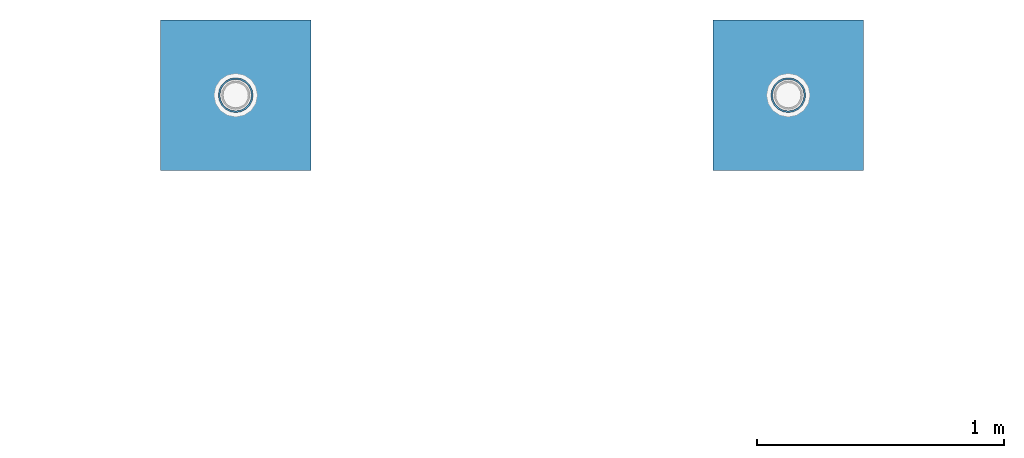
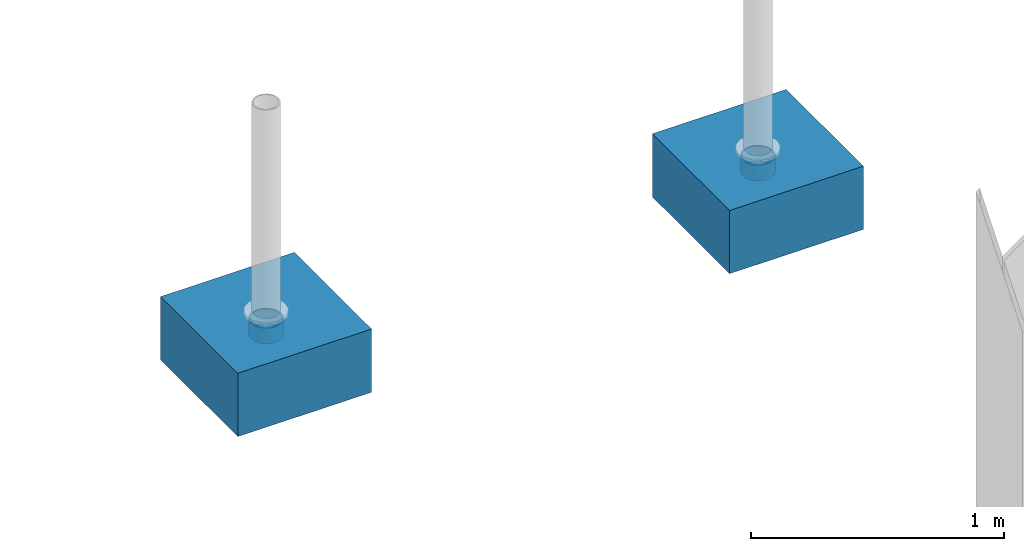
# One storey, part 1607 of 3843: 4 columns, 4 elements without a shape of their own.
"""IFC2X3 building model written with IfcOpenShell, lengths in millimetres."""

from ifc_helpers import new_model, si_unit, frame, origin_with_axes, place, context, subcontext, project, spatial, faceted_brep, material, type_object, element, aggregate, save


model = new_model("IFC2X3")

# Units and contexts
model_context = context("Model", 3, precision=1e-05, world=origin_with_axes())
body_context = subcontext(model_context, "Body", "Model", "MODEL_VIEW")
ifc_project = project(units=[si_unit("LENGTHUNIT", "METRE", prefix="MILLI"), si_unit("AREAUNIT", "SQUARE_METRE"), si_unit("VOLUMEUNIT", "CUBIC_METRE"), si_unit("MASSUNIT", "GRAM", prefix="KILO"), si_unit("TIMEUNIT", "SECOND"), si_unit("PLANEANGLEUNIT", "RADIAN"), si_unit("SOLIDANGLEUNIT", "STERADIAN"), si_unit("THERMODYNAMICTEMPERATUREUNIT", "DEGREE_CELSIUS"), si_unit("LUMINOUSINTENSITYUNIT", "LUMEN")], contexts=[model_context])

# Site, building, storey
site_placement = place(None, origin_with_axes())
site = spatial("IfcSite", under=ifc_project, at=site_placement, CompositionType="ELEMENT")
building_placement = place(site_placement, origin_with_axes())
building = spatial("IfcBuilding", under=site, at=building_placement, Name="Undefined", CompositionType="ELEMENT")
storey_placement = place(building_placement, origin_with_axes())
storey = spatial("IfcBuildingStorey", under=building, at=storey_placement, Name="Undefined", CompositionType="ELEMENT", Elevation=0.0)

# Assembly, column
assembly_1_placement = place(storey_placement, origin_with_axes())
assembly_1 = element("IfcElementAssembly", 1, at=assembly_1_placement, inside=storey, Name="PLATE", AssemblyPlace="NOTDEFINED", PredefinedType="RIGID_FRAME")
ifc_material_1 = material()
column_type_1 = type_object("IfcColumnType", Name="PIPE5SCH40", PredefinedType="NOTDEFINED")
column_1_placement = place(assembly_1_placement, frame((77051.0673368275, 106838.978119135, 30378.4), z_axis=(-1.0, 0.0, 0.0), x_axis=(0.0, 0.0, 1.0)))
column_1 = element("IfcColumn", 2, at=column_1_placement, type_object=column_type_1, material=ifc_material_1, Name="PIPE_SLEEVE", ObjectType="PIPE5SCH40", context=body_context, shape_type="Brep", body=[
    faceted_brep([(0.0, -64.0587999999998, 0.0), (0.0, -60.9235391660477, 19.7952578392724), (76.2000000000007, -60.9235391660477, 19.7952578392724), (76.2000000000007, -64.0587999999998, 0.0), (0.0, -51.8246578392655, 37.6528179195593), (76.2000000000007, -51.8246578392655, 37.6528179195593), (0.0, -37.6528179195529, 51.8246578392718), (76.2000000000007, -37.6528179195529, 51.8246578392718), (0.0, -19.795257839266, 60.9235391660477), (76.2000000000007, -19.795257839266, 60.9235391660477), (0.0, 0.0, 64.0587999999989), (76.2000000000007, 0.0, 64.0587999999989), (0.0, 19.795257839266, 60.9235391660477), (76.2000000000007, 19.795257839266, 60.9235391660477), (0.0, 37.6528179195529, 51.8246578392718), (76.2000000000007, 37.6528179195529, 51.8246578392718), (0.0, 51.8246578392655, 37.6528179195593), (76.2000000000007, 51.8246578392655, 37.6528179195593), (0.0, 60.9235391660477, 19.7952578392724), (76.2000000000007, 60.9235391660477, 19.7952578392724), (0.0, 64.0587999999998, 0.0), (76.2000000000007, 64.0587999999998, 0.0), (0.0, 60.9235391660477, -19.7952578392724), (76.2000000000007, 60.9235391660477, -19.7952578392724), (0.0, 51.8246578392655, -37.6528179195593), (76.2000000000007, 51.8246578392655, -37.6528179195593), (0.0, 37.6528179195529, -51.8246578392718), (76.2000000000007, 37.6528179195529, -51.8246578392718), (0.0, 19.795257839266, -60.9235391660477), (76.2000000000007, 19.795257839266, -60.9235391660477), (0.0, 0.0, -64.0587999999989), (76.2000000000007, 0.0, -64.0587999999989), (0.0, -19.795257839266, -60.9235391660477), (76.2000000000007, -19.795257839266, -60.9235391660477), (0.0, -37.6528179195529, -51.8246578392718), (76.2000000000007, -37.6528179195529, -51.8246578392718), (0.0, -51.8246578392655, -37.6528179195593), (76.2000000000007, -51.8246578392655, -37.6528179195593), (0.0, -60.9235391660477, -19.7952578392724), (76.2000000000007, -60.9235391660477, -19.7952578392724), (0.0, -70.6120000000001, 0.0), (0.0, -67.1560027286332, -21.8203080068051), (76.2000000000007, -67.1560027286332, -21.8203080068051), (76.2000000000007, -70.6120000000001, 0.0), (0.0, -57.1263080068038, -41.5046922348702), (76.2000000000007, -57.1263080068038, -41.5046922348702), (0.0, -41.5046922348765, -57.126308006802), (76.2000000000007, -41.5046922348765, -57.126308006802), (0.0, -21.8203080068042, -67.1560027286323), (76.2000000000007, -21.8203080068042, -67.1560027286323), (0.0, 0.0, -70.6119999999937), (76.2000000000007, 0.0, -70.6119999999937), (0.0, 21.8203080068042, -67.1560027286323), (76.2000000000007, 21.8203080068042, -67.1560027286323), (0.0, 41.5046922348765, -57.126308006802), (76.2000000000007, 41.5046922348765, -57.126308006802), (0.0, 57.1263080068038, -41.5046922348702), (76.2000000000007, 57.1263080068038, -41.5046922348702), (0.0, 67.1560027286332, -21.8203080068051), (76.2000000000007, 67.1560027286332, -21.8203080068051), (0.0, 70.6120000000001, 0.0), (76.2000000000007, 70.6120000000001, 0.0), (0.0, 67.1560027286332, 21.8203080068051), (76.2000000000007, 67.1560027286332, 21.8203080068051), (0.0, 57.1263080068038, 41.5046922348702), (76.2000000000007, 57.1263080068038, 41.5046922348702), (0.0, 41.5046922348765, 57.126308006802), (76.2000000000007, 41.5046922348765, 57.126308006802), (0.0, 21.8203080068042, 67.1560027286323), (76.2000000000007, 21.8203080068042, 67.1560027286323), (0.0, 0.0, 70.6119999999937), (76.2000000000007, 0.0, 70.6119999999937), (0.0, -21.8203080068042, 67.1560027286323), (76.2000000000007, -21.8203080068042, 67.1560027286323), (0.0, -41.5046922348765, 57.126308006802), (76.2000000000007, -41.5046922348765, 57.126308006802), (0.0, -57.1263080068038, 41.5046922348702), (76.2000000000007, -57.1263080068038, 41.5046922348702), (0.0, -67.1560027286332, 21.8203080068051), (76.2000000000007, -67.1560027286332, 21.8203080068051)], [[[0, 1, 2, 3]], [[1, 4, 5, 2]], [[4, 6, 7, 5]], [[6, 8, 9, 7]], [[8, 10, 11, 9]], [[10, 12, 13, 11]], [[12, 14, 15, 13]], [[14, 16, 17, 15]], [[16, 18, 19, 17]], [[18, 20, 21, 19]], [[20, 22, 23, 21]], [[22, 24, 25, 23]], [[24, 26, 27, 25]], [[26, 28, 29, 27]], [[28, 30, 31, 29]], [[30, 32, 33, 31]], [[32, 34, 35, 33]], [[34, 36, 37, 35]], [[36, 38, 39, 37]], [[38, 0, 3, 39]], [[40, 41, 42, 43]], [[41, 44, 45, 42]], [[44, 46, 47, 45]], [[46, 48, 49, 47]], [[48, 50, 51, 49]], [[50, 52, 53, 51]], [[52, 54, 55, 53]], [[54, 56, 57, 55]], [[56, 58, 59, 57]], [[58, 60, 61, 59]], [[60, 62, 63, 61]], [[62, 64, 65, 63]], [[64, 66, 67, 65]], [[66, 68, 69, 67]], [[68, 70, 71, 69]], [[70, 72, 73, 71]], [[72, 74, 75, 73]], [[74, 76, 77, 75]], [[76, 78, 79, 77]], [[78, 40, 43, 79]], [[45, 47, 49, 51, 53, 55, 57, 59, 61, 63, 65, 67, 69, 71, 73, 75, 77, 79, 43, 42], [5, 7, 9, 11, 13, 15, 17, 19, 21, 23, 25, 27, 29, 31, 33, 35, 37, 39, 3, 2]], [[78, 76, 74, 72, 70, 68, 66, 64, 62, 60, 58, 56, 54, 52, 50, 48, 46, 44, 41, 40], [38, 36, 34, 32, 30, 28, 26, 24, 22, 20, 18, 16, 14, 12, 10, 8, 6, 4, 1, 0]]]),
])
aggregate(assembly_1, [column_1])

assembly_2_placement = place(storey_placement, origin_with_axes())
assembly_2 = element("IfcElementAssembly", 3, at=assembly_2_placement, inside=storey, Name="PLATE", AssemblyPlace="NOTDEFINED", PredefinedType="RIGID_FRAME")
column_2_placement = place(assembly_2_placement, frame((74809.6237027943, 106838.981933832, 30378.4), z_axis=(-1.0, 0.0, 0.0), x_axis=(0.0, 0.0, 1.0)))
column_2 = element("IfcColumn", 4, at=column_2_placement, type_object=column_type_1, material=ifc_material_1, Name="PIPE_SLEEVE", ObjectType="PIPE5SCH40", context=body_context, shape_type="Brep", body=[
    faceted_brep([(0.0, -64.0587999999998, 0.0), (0.0, -60.9235391660477, 19.7952578392724), (76.2000000000007, -60.9235391660477, 19.7952578392724), (76.2000000000007, -64.0587999999998, 0.0), (0.0, -51.8246578392655, 37.6528179195593), (76.2000000000007, -51.8246578392655, 37.6528179195593), (0.0, -37.6528179195529, 51.8246578392718), (76.2000000000007, -37.6528179195529, 51.8246578392718), (0.0, -19.795257839266, 60.9235391660477), (76.2000000000007, -19.795257839266, 60.9235391660477), (0.0, 0.0, 64.0587999999989), (76.2000000000007, 0.0, 64.0587999999989), (0.0, 19.795257839266, 60.9235391660477), (76.2000000000007, 19.795257839266, 60.9235391660477), (0.0, 37.6528179195529, 51.8246578392718), (76.2000000000007, 37.6528179195529, 51.8246578392718), (0.0, 51.8246578392655, 37.6528179195593), (76.2000000000007, 51.8246578392655, 37.6528179195593), (0.0, 60.9235391660477, 19.7952578392724), (76.2000000000007, 60.9235391660477, 19.7952578392724), (0.0, 64.0587999999998, 0.0), (76.2000000000007, 64.0587999999998, 0.0), (0.0, 60.9235391660477, -19.7952578392724), (76.2000000000007, 60.9235391660477, -19.7952578392724), (0.0, 51.8246578392655, -37.6528179195593), (76.2000000000007, 51.8246578392655, -37.6528179195593), (0.0, 37.6528179195529, -51.8246578392718), (76.2000000000007, 37.6528179195529, -51.8246578392718), (0.0, 19.795257839266, -60.9235391660477), (76.2000000000007, 19.795257839266, -60.9235391660477), (0.0, 0.0, -64.0587999999989), (76.2000000000007, 0.0, -64.0587999999989), (0.0, -19.795257839266, -60.9235391660477), (76.2000000000007, -19.795257839266, -60.9235391660477), (0.0, -37.6528179195529, -51.8246578392718), (76.2000000000007, -37.6528179195529, -51.8246578392718), (0.0, -51.8246578392655, -37.6528179195593), (76.2000000000007, -51.8246578392655, -37.6528179195593), (0.0, -60.9235391660477, -19.7952578392724), (76.2000000000007, -60.9235391660477, -19.7952578392724), (0.0, -70.6120000000001, 0.0), (0.0, -67.1560027286332, -21.8203080068051), (76.2000000000007, -67.1560027286332, -21.8203080068051), (76.2000000000007, -70.6120000000001, 0.0), (0.0, -57.1263080068038, -41.5046922348702), (76.2000000000007, -57.1263080068038, -41.5046922348702), (0.0, -41.5046922348765, -57.126308006802), (76.2000000000007, -41.5046922348765, -57.126308006802), (0.0, -21.8203080068042, -67.1560027286323), (76.2000000000007, -21.8203080068042, -67.1560027286323), (0.0, 0.0, -70.6119999999937), (76.2000000000007, 0.0, -70.6119999999937), (0.0, 21.8203080068042, -67.1560027286323), (76.2000000000007, 21.8203080068042, -67.1560027286323), (0.0, 41.5046922348765, -57.126308006802), (76.2000000000007, 41.5046922348765, -57.126308006802), (0.0, 57.1263080068038, -41.5046922348702), (76.2000000000007, 57.1263080068038, -41.5046922348702), (0.0, 67.1560027286332, -21.8203080068051), (76.2000000000007, 67.1560027286332, -21.8203080068051), (0.0, 70.6120000000001, 0.0), (76.2000000000007, 70.6120000000001, 0.0), (0.0, 67.1560027286332, 21.8203080068051), (76.2000000000007, 67.1560027286332, 21.8203080068051), (0.0, 57.1263080068038, 41.5046922348702), (76.2000000000007, 57.1263080068038, 41.5046922348702), (0.0, 41.5046922348765, 57.126308006802), (76.2000000000007, 41.5046922348765, 57.126308006802), (0.0, 21.8203080068042, 67.1560027286323), (76.2000000000007, 21.8203080068042, 67.1560027286323), (0.0, 0.0, 70.6119999999937), (76.2000000000007, 0.0, 70.6119999999937), (0.0, -21.8203080068042, 67.1560027286323), (76.2000000000007, -21.8203080068042, 67.1560027286323), (0.0, -41.5046922348765, 57.126308006802), (76.2000000000007, -41.5046922348765, 57.126308006802), (0.0, -57.1263080068038, 41.5046922348702), (76.2000000000007, -57.1263080068038, 41.5046922348702), (0.0, -67.1560027286332, 21.8203080068051), (76.2000000000007, -67.1560027286332, 21.8203080068051)], [[[0, 1, 2, 3]], [[1, 4, 5, 2]], [[4, 6, 7, 5]], [[6, 8, 9, 7]], [[8, 10, 11, 9]], [[10, 12, 13, 11]], [[12, 14, 15, 13]], [[14, 16, 17, 15]], [[16, 18, 19, 17]], [[18, 20, 21, 19]], [[20, 22, 23, 21]], [[22, 24, 25, 23]], [[24, 26, 27, 25]], [[26, 28, 29, 27]], [[28, 30, 31, 29]], [[30, 32, 33, 31]], [[32, 34, 35, 33]], [[34, 36, 37, 35]], [[36, 38, 39, 37]], [[38, 0, 3, 39]], [[40, 41, 42, 43]], [[41, 44, 45, 42]], [[44, 46, 47, 45]], [[46, 48, 49, 47]], [[48, 50, 51, 49]], [[50, 52, 53, 51]], [[52, 54, 55, 53]], [[54, 56, 57, 55]], [[56, 58, 59, 57]], [[58, 60, 61, 59]], [[60, 62, 63, 61]], [[62, 64, 65, 63]], [[64, 66, 67, 65]], [[66, 68, 69, 67]], [[68, 70, 71, 69]], [[70, 72, 73, 71]], [[72, 74, 75, 73]], [[74, 76, 77, 75]], [[76, 78, 79, 77]], [[78, 40, 43, 79]], [[45, 47, 49, 51, 53, 55, 57, 59, 61, 63, 65, 67, 69, 71, 73, 75, 77, 79, 43, 42], [5, 7, 9, 11, 13, 15, 17, 19, 21, 23, 25, 27, 29, 31, 33, 35, 37, 39, 3, 2]], [[78, 76, 74, 72, 70, 68, 66, 64, 62, 60, 58, 56, 54, 52, 50, 48, 46, 44, 41, 40], [38, 36, 34, 32, 30, 28, 26, 24, 22, 20, 18, 16, 14, 12, 10, 8, 6, 4, 1, 0]]]),
])
aggregate(assembly_2, [column_2])

assembly_3_placement = place(storey_placement, origin_with_axes())
assembly_3 = element("IfcElementAssembly", 5, at=assembly_3_placement, inside=storey, Name="CONC_COL.", AssemblyPlace="NOTDEFINED", PredefinedType="REINFORCEMENT_UNIT")
ifc_material_2 = material(Name="CONCRETE/3000")
column_type_2 = type_object("IfcColumnType", PredefinedType="NOTDEFINED")
column_3_placement = place(assembly_3_placement, frame((77051.0673368275, 106838.978119135, 30175.2), z_axis=(-1.0, 0.0, 0.0), x_axis=(0.0, 0.0, 1.0)))
column_3 = element("IfcColumn", 6, at=column_3_placement, type_object=column_type_2, material=ifc_material_2, Name="CONC_COL.", context=body_context, shape_type="Brep", body=[
    faceted_brep([(0.0, 304.8, -304.800000000003), (0.0, 304.8, 304.800000000003), (304.799999999999, 304.8, 304.800000000003), (304.799999999999, 304.8, -304.800000000003), (0.0, -304.8, 304.800000000003), (304.799999999999, -304.8, 304.800000000003), (0.0, -304.8, -304.800000000003), (304.799999999999, -304.8, -304.800000000003)], [[[0, 1, 2, 3]], [[1, 4, 5, 2]], [[4, 6, 7, 5]], [[6, 0, 3, 7]], [[5, 7, 3, 2]], [[6, 4, 1, 0]]]),
])
aggregate(assembly_3, [column_3])

assembly_4_placement = place(storey_placement, origin_with_axes())
assembly_4 = element("IfcElementAssembly", 7, at=assembly_4_placement, inside=storey, Name="CONC_COL.", AssemblyPlace="NOTDEFINED", PredefinedType="REINFORCEMENT_UNIT")
column_4_placement = place(assembly_4_placement, frame((74809.6237027943, 106838.981933832, 30175.2), z_axis=(-1.0, 0.0, 0.0), x_axis=(0.0, 0.0, 1.0)))
column_4 = element("IfcColumn", 8, at=column_4_placement, type_object=column_type_2, material=ifc_material_2, Name="CONC_COL.", context=body_context, shape_type="Brep", body=[
    faceted_brep([(0.0, 304.8, -304.800000000003), (0.0, 304.8, 304.800000000003), (304.799999999999, 304.8, 304.800000000003), (304.799999999999, 304.8, -304.800000000003), (0.0, -304.8, 304.800000000003), (304.799999999999, -304.8, 304.800000000003), (0.0, -304.8, -304.800000000003), (304.799999999999, -304.8, -304.800000000003)], [[[0, 1, 2, 3]], [[1, 4, 5, 2]], [[4, 6, 7, 5]], [[6, 0, 3, 7]], [[5, 7, 3, 2]], [[6, 4, 1, 0]]]),
])
aggregate(assembly_4, [column_4])

save(model, "model.ifc")
